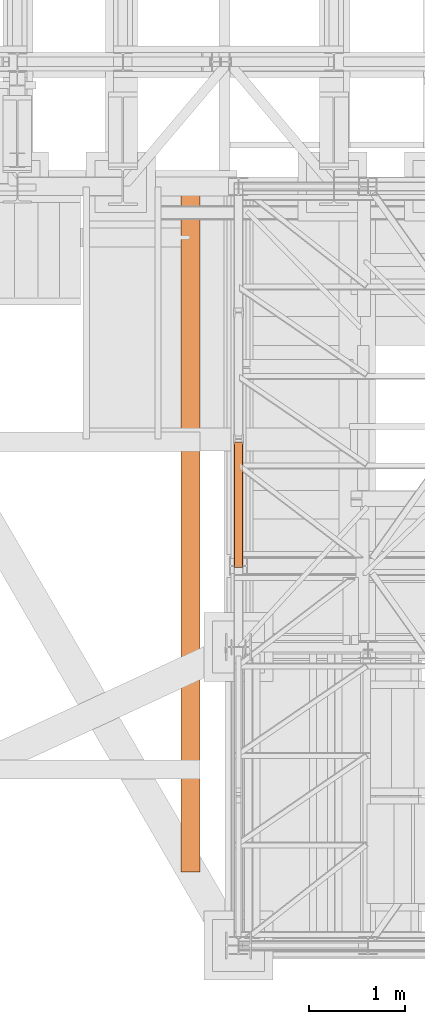
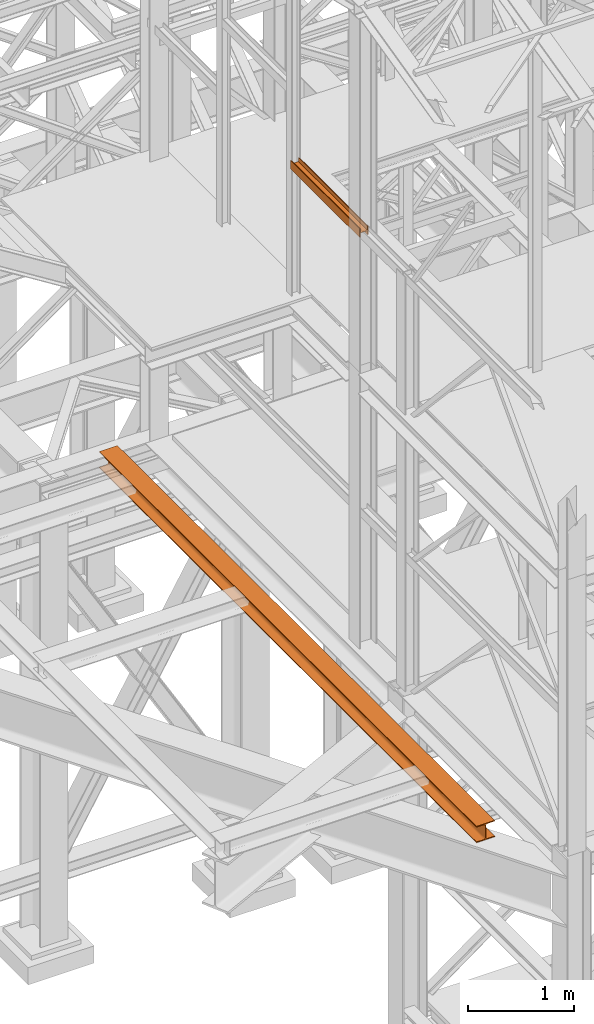
# One storey, part 24 of 208: 3 proxies.
"""IFC2X3 building model written with IfcOpenShell, lengths in millimetres."""

from ifc_helpers import new_model, entity, si_unit, converted_unit, frame, origin, origin_with_axes, place, context, subcontext, project, spatial, faceted_brep, element, save


model = new_model("IFC2X3")

# Units and contexts
model_context = context("Model", 3, precision=1e-05, world=origin())
plan_context = context("Plan", 3, precision=1e-05, world=origin())
body_context = subcontext(model_context, "Body", "Model", "MODEL_VIEW")
ifc_project = project(units=[si_unit("LENGTHUNIT", "METRE", prefix="MILLI"), converted_unit("PLANEANGLEUNIT", "DEGREE", entity("IfcPlaneAngleMeasure", 0.0174532925199433), si_unit("PLANEANGLEUNIT", "RADIAN"), dimensions=[0, 0, 0, 0, 0, 0, 0]), si_unit("AREAUNIT", "SQUARE_METRE"), si_unit("VOLUMEUNIT", "CUBIC_METRE")], contexts=[model_context, plan_context])

# Building, storey
building_placement = place(None, origin())
building = spatial("IfcBuilding", under=ifc_project, at=building_placement, CompositionType="COMPLEX")
storey_placement = place(building_placement, origin_with_axes())
storey = spatial("IfcBuildingStorey", under=building, at=storey_placement, Name="Geschoss", CompositionType="ELEMENT")

# Proxies
proxy_1_placement = place(storey_placement, frame((1150.254968528656, -21234.96003231041, 9977.249663113742), z_axis=(0.0, 0.0, 1.0), x_axis=(1.0, 0.0, 0.0)))
element("IfcBuildingElementProxy", 1, at=proxy_1_placement, inside=storey, context=body_context, shape_type="Brep", body=[
    faceted_brep([(8.009999999999991, 0.00999999999839929, 0.01000000000021828), (0.009999999999990905, 0.00999999999839929, 0.01000000000021828), (0.009999999999990905, 0.00999999999839929, 100.0100000000002), (8.009999999999991, 0.00999999999839929, 100.0100000000002), (8.009999999999991, 0.00999999999839929, 52.51000000000022), (88.00999999999999, 0.00999999999839929, 52.51000000000022), (88.00999999999999, 0.00999999999839929, 100.0100000000002), (96.00999999999999, 0.00999999999839929, 100.0100000000002), (96.00999999999999, 0.00999999999839929, 0.01000000000021828), (88.00999999999999, 0.00999999999839929, 0.01000000000021828), (88.00999999999999, 0.00999999999839929, 47.51000000000022), (8.009999999999991, 0.00999999999839929, 47.51000000000022), (0.009999999999990905, 0.00999999999839929, 0.01000000000021828), (8.009999999999991, 0.00999999999839929, 0.01000000000021828), (8.009999999999991, 1312.395641619994, 0.01000000000021828), (0.009999999999990905, 1312.395641619994, 0.01000000000021828), (0.009999999999990905, 0.00999999999839929, 100.0100000000002), (0.009999999999990905, 0.00999999999839929, 0.01000000000021828), (0.009999999999990905, 1312.395641619994, 0.01000000000021828), (0.009999999999990905, 1312.395641619994, 100.0100000000002), (8.009999999999991, 0.00999999999839929, 100.0100000000002), (0.009999999999990905, 0.00999999999839929, 100.0100000000002), (0.009999999999990905, 1312.395641619994, 100.0100000000002), (8.009999999999991, 1312.395641619994, 100.0100000000002), (8.009999999999991, 0.00999999999839929, 52.51000000000022), (8.009999999999991, 0.00999999999839929, 100.0100000000002), (8.009999999999991, 1312.395641619994, 100.0100000000002), (8.009999999999991, 1312.395641619994, 52.51000000000022), (88.00999999999999, 0.00999999999839929, 52.51000000000022), (8.009999999999991, 0.00999999999839929, 52.51000000000022), (8.009999999999991, 1312.395641619994, 52.51000000000022), (88.00999999999999, 1312.395641619994, 52.51000000000022), (88.00999999999999, 0.00999999999839929, 100.0100000000002), (88.00999999999999, 0.00999999999839929, 52.51000000000022), (88.00999999999999, 1312.395641619994, 52.51000000000022), (88.00999999999999, 1312.395641619994, 100.0100000000002), (96.00999999999999, 0.00999999999839929, 100.0100000000002), (88.00999999999999, 0.00999999999839929, 100.0100000000002), (88.00999999999999, 1312.395641619994, 100.0100000000002), (96.00999999999999, 1312.395641619994, 100.0100000000002), (96.00999999999999, 0.00999999999839929, 0.01000000000021828), (96.00999999999999, 0.00999999999839929, 100.0100000000002), (96.00999999999999, 1312.395641619994, 100.0100000000002), (96.00999999999999, 1312.395641619994, 0.01000000000021828), (88.00999999999999, 0.00999999999839929, 0.01000000000021828), (96.00999999999999, 0.00999999999839929, 0.01000000000021828), (96.00999999999999, 1312.395641619994, 0.01000000000021828), (88.00999999999999, 1312.395641619994, 0.01000000000021828), (88.00999999999999, 0.00999999999839929, 47.51000000000022), (88.00999999999999, 0.00999999999839929, 0.01000000000021828), (88.00999999999999, 1312.395641619994, 0.01000000000021828), (88.00999999999999, 1312.395641619994, 47.51000000000022), (8.009999999999991, 0.00999999999839929, 47.51000000000022), (88.00999999999999, 0.00999999999839929, 47.51000000000022), (88.00999999999999, 1312.395641619994, 47.51000000000022), (8.009999999999991, 1312.395641619994, 47.51000000000022), (8.009999999999991, 0.00999999999839929, 0.01000000000021828), (8.009999999999991, 0.00999999999839929, 47.51000000000022), (8.009999999999991, 1312.395641619994, 47.51000000000022), (8.009999999999991, 1312.395641619994, 0.01000000000021828), (8.009999999999991, 1312.395641619994, 0.01000000000021828), (8.009999999999991, 1312.395641619994, 47.51000000000022), (88.00999999999999, 1312.395641619994, 47.51000000000022), (88.00999999999999, 1312.395641619994, 0.01000000000021828), (96.00999999999999, 1312.395641619994, 0.01000000000021828), (96.00999999999999, 1312.395641619994, 100.0100000000002), (88.00999999999999, 1312.395641619994, 100.0100000000002), (88.00999999999999, 1312.395641619994, 52.51000000000022), (8.009999999999991, 1312.395641619994, 52.51000000000022), (8.009999999999991, 1312.395641619994, 100.0100000000002), (0.009999999999990905, 1312.395641619994, 100.0100000000002), (0.009999999999990905, 1312.395641619994, 0.01000000000021828)], [[[0, 1, 2, 3, 4, 5, 6, 7, 8, 9, 10, 11]], [[12, 13, 14, 15]], [[16, 17, 18, 19]], [[20, 21, 22, 23]], [[24, 25, 26, 27]], [[28, 29, 30, 31]], [[32, 33, 34, 35]], [[36, 37, 38, 39]], [[40, 41, 42, 43]], [[44, 45, 46, 47]], [[48, 49, 50, 51]], [[52, 53, 54, 55]], [[56, 57, 58, 59]], [[60, 61, 62, 63, 64, 65, 66, 67, 68, 69, 70, 71]]], orient=[[False], [False], [False], [False], [False], [False], [False], [False], [False], [False], [False], [False], [False], [False]]),
])
proxy_2_placement = place(storey_placement, frame((1150.254968528656, -21234.96003231041, 9977.249663113742), z_axis=(0.0, 0.0, 1.0), x_axis=(1.0, 0.0, 0.0)))
element("IfcBuildingElementProxy", 2, at=proxy_2_placement, inside=storey, context=body_context, shape_type="Brep", body=[
    faceted_brep([(8.009999999999991, 0.00999999999839929, 0.01000000000021828), (0.009999999999990905, 0.00999999999839929, 0.01000000000021828), (0.009999999999990905, 0.00999999999839929, 100.0100000000002), (8.009999999999991, 0.00999999999839929, 100.0100000000002), (8.009999999999991, 0.00999999999839929, 52.51000000000022), (88.00999999999999, 0.00999999999839929, 52.51000000000022), (88.00999999999999, 0.00999999999839929, 100.0100000000002), (96.00999999999999, 0.00999999999839929, 100.0100000000002), (96.00999999999999, 0.00999999999839929, 0.01000000000021828), (88.00999999999999, 0.00999999999839929, 0.01000000000021828), (88.00999999999999, 0.00999999999839929, 47.51000000000022), (8.009999999999991, 0.00999999999839929, 47.51000000000022), (0.009999999999990905, 0.00999999999839929, 0.01000000000021828), (8.009999999999991, 0.00999999999839929, 0.01000000000021828), (8.009999999999991, 1312.395641619994, 0.01000000000021828), (0.009999999999990905, 1312.395641619994, 0.01000000000021828), (0.009999999999990905, 0.00999999999839929, 100.0100000000002), (0.009999999999990905, 0.00999999999839929, 0.01000000000021828), (0.009999999999990905, 1312.395641619994, 0.01000000000021828), (0.009999999999990905, 1312.395641619994, 100.0100000000002), (8.009999999999991, 0.00999999999839929, 100.0100000000002), (0.009999999999990905, 0.00999999999839929, 100.0100000000002), (0.009999999999990905, 1312.395641619994, 100.0100000000002), (8.009999999999991, 1312.395641619994, 100.0100000000002), (8.009999999999991, 0.00999999999839929, 52.51000000000022), (8.009999999999991, 0.00999999999839929, 100.0100000000002), (8.009999999999991, 1312.395641619994, 100.0100000000002), (8.009999999999991, 1312.395641619994, 52.51000000000022), (88.00999999999999, 0.00999999999839929, 52.51000000000022), (8.009999999999991, 0.00999999999839929, 52.51000000000022), (8.009999999999991, 1312.395641619994, 52.51000000000022), (88.00999999999999, 1312.395641619994, 52.51000000000022), (88.00999999999999, 0.00999999999839929, 100.0100000000002), (88.00999999999999, 0.00999999999839929, 52.51000000000022), (88.00999999999999, 1312.395641619994, 52.51000000000022), (88.00999999999999, 1312.395641619994, 100.0100000000002), (96.00999999999999, 0.00999999999839929, 100.0100000000002), (88.00999999999999, 0.00999999999839929, 100.0100000000002), (88.00999999999999, 1312.395641619994, 100.0100000000002), (96.00999999999999, 1312.395641619994, 100.0100000000002), (96.00999999999999, 0.00999999999839929, 0.01000000000021828), (96.00999999999999, 0.00999999999839929, 100.0100000000002), (96.00999999999999, 1312.395641619994, 100.0100000000002), (96.00999999999999, 1312.395641619994, 0.01000000000021828), (88.00999999999999, 0.00999999999839929, 0.01000000000021828), (96.00999999999999, 0.00999999999839929, 0.01000000000021828), (96.00999999999999, 1312.395641619994, 0.01000000000021828), (88.00999999999999, 1312.395641619994, 0.01000000000021828), (88.00999999999999, 0.00999999999839929, 47.51000000000022), (88.00999999999999, 0.00999999999839929, 0.01000000000021828), (88.00999999999999, 1312.395641619994, 0.01000000000021828), (88.00999999999999, 1312.395641619994, 47.51000000000022), (8.009999999999991, 0.00999999999839929, 47.51000000000022), (88.00999999999999, 0.00999999999839929, 47.51000000000022), (88.00999999999999, 1312.395641619994, 47.51000000000022), (8.009999999999991, 1312.395641619994, 47.51000000000022), (8.009999999999991, 0.00999999999839929, 0.01000000000021828), (8.009999999999991, 0.00999999999839929, 47.51000000000022), (8.009999999999991, 1312.395641619994, 47.51000000000022), (8.009999999999991, 1312.395641619994, 0.01000000000021828), (8.009999999999991, 1312.395641619994, 0.01000000000021828), (8.009999999999991, 1312.395641619994, 47.51000000000022), (88.00999999999999, 1312.395641619994, 47.51000000000022), (88.00999999999999, 1312.395641619994, 0.01000000000021828), (96.00999999999999, 1312.395641619994, 0.01000000000021828), (96.00999999999999, 1312.395641619994, 100.0100000000002), (88.00999999999999, 1312.395641619994, 100.0100000000002), (88.00999999999999, 1312.395641619994, 52.51000000000022), (8.009999999999991, 1312.395641619994, 52.51000000000022), (8.009999999999991, 1312.395641619994, 100.0100000000002), (0.009999999999990905, 1312.395641619994, 100.0100000000002), (0.009999999999990905, 1312.395641619994, 0.01000000000021828)], [[[0, 1, 2, 3, 4, 5, 6, 7, 8, 9, 10, 11]], [[12, 13, 14, 15]], [[16, 17, 18, 19]], [[20, 21, 22, 23]], [[24, 25, 26, 27]], [[28, 29, 30, 31]], [[32, 33, 34, 35]], [[36, 37, 38, 39]], [[40, 41, 42, 43]], [[44, 45, 46, 47]], [[48, 49, 50, 51]], [[52, 53, 54, 55]], [[56, 57, 58, 59]], [[60, 61, 62, 63, 64, 65, 66, 67, 68, 69, 70, 71]]], orient=[[False], [False], [False], [False], [False], [False], [False], [False], [False], [False], [False], [False], [False], [False]]),
])
proxy_3_placement = place(storey_placement, frame((598.2549685286633, -24404.76773812424, 5094.990005364416), z_axis=(0.0, 0.0, 1.0), x_axis=(1.0, 0.0, 0.0)))
element("IfcBuildingElementProxy", 3, at=proxy_3_placement, inside=storey, context=body_context, shape_type="Brep", body=[
    faceted_brep([(200.01, 7147.273876318883, 0.01000000000021828), (200.0099999999991, 0.01000000000203727, 0.01000000000021828), (200.0099999999991, 0.01000000000203727, 10.01000000000022), (200.01, 7147.273876318883, 10.01000000000022), (200.01, 7147.273876318883, 10.01000000000022), (200.0099999999991, 0.01000000000203727, 10.01000000000022), (121.2599999999991, 0.01000000000203727, 10.01000000000022), (121.26, 7147.273876318883, 10.01000000000022), (121.26, 7147.273876318883, 10.01000000000022), (121.2599999999991, 0.01000000000203727, 10.01000000000022), (115.6977129694249, 0.01000000000203727, 10.89104403849342), (115.6977129694258, 7147.273876318883, 10.89104403849342), (115.6977129694258, 7147.273876318883, 10.89104403849342), (115.6977129694249, 0.01000000000203727, 10.89104403849342), (110.6798832894644, 0.01000000000203727, 13.44771635773213), (110.6798832894654, 7147.273876318883, 13.44771635773213), (110.6798832894654, 7147.273876318883, 13.44771635773213), (110.6798832894644, 0.01000000000203727, 13.44771635773213), (106.6977163577328, 0.01000000000203727, 17.42988328946558), (106.6977163577337, 7147.273876318883, 17.42988328946558), (106.6977163577337, 7147.273876318883, 17.42988328946558), (106.6977163577328, 0.01000000000203727, 17.42988328946558), (104.1410440384941, 0.01000000000203727, 22.44771296942599), (104.141044038495, 7147.273876318883, 22.44771296942599), (104.141044038495, 7147.273876318883, 22.44771296942599), (104.1410440384941, 0.01000000000203727, 22.44771296942599), (103.2599999999991, 0.01000000000203727, 28.01000000000022), (103.26, 7147.273876318883, 28.01000000000022), (103.26, 7147.273876318883, 28.01000000000022), (103.2599999999991, 0.01000000000203727, 28.01000000000022), (103.2599999999991, 0.01000000000203727, 162.0100000000002), (103.26, 7147.273876318883, 162.0100000000002), (103.26, 7147.273876318883, 162.0100000000002), (103.2599999999991, 0.01000000000203727, 162.0100000000002), (104.1410440384941, 0.01000000000203727, 167.5722870305744), (104.141044038495, 7147.273876318883, 167.5722870305744), (104.141044038495, 7147.273876318883, 167.5722870305744), (104.1410440384941, 0.01000000000203727, 167.5722870305744), (106.6977163577328, 0.01000000000203727, 172.5901167105349), (106.6977163577337, 7147.273876318883, 172.5901167105349), (106.6977163577337, 7147.273876318883, 172.5901167105349), (106.6977163577328, 0.01000000000203727, 172.5901167105349), (110.6798832894644, 0.01000000000203727, 176.5722836422683), (110.6798832894654, 7147.273876318883, 176.5722836422683), (110.6798832894654, 7147.273876318883, 176.5722836422683), (110.6798832894644, 0.01000000000203727, 176.5722836422683), (115.6977129694249, 0.01000000000203727, 179.128955961507), (115.6977129694258, 7147.273876318883, 179.128955961507), (115.6977129694258, 7147.273876318883, 179.128955961507), (115.6977129694249, 0.01000000000203727, 179.128955961507), (120.0099999999991, 0.01000000000203727, 180.0100000000002), (120.01, 7147.273876318883, 180.0100000000002), (120.01, 7147.273876318883, 180.0100000000002), (120.0099999999991, 0.01000000000203727, 180.0100000000002), (200.0099999999991, 0.01000000000203727, 180.0100000000002), (200.01, 7147.273876318883, 180.0100000000002), (200.01, 7147.273876318883, 180.0100000000002), (200.0099999999991, 0.01000000000203727, 180.0100000000002), (200.0099999999991, 0.01000000000203727, 190.0100000000002), (200.01, 7147.273876318883, 190.0100000000002), (200.01, 7147.273876318883, 190.0100000000002), (200.0099999999991, 0.01000000000203727, 190.0100000000002), (0.009999999999990905, 0.01000000000203727, 190.0100000000002), (0.009999999999990905, 7147.273876318883, 190.0100000000002), (0.009999999999990905, 7147.273876318883, 190.0100000000002), (0.009999999999990905, 0.01000000000203727, 190.0100000000002), (0.009999999999990905, 0.01000000000203727, 180.0100000000002), (0.009999999999990905, 7147.273876318883, 180.0100000000002), (0.009999999999990905, 7147.273876318883, 180.0100000000002), (0.009999999999990905, 0.01000000000203727, 180.0100000000002), (78.75999999999908, 0.01000000000203727, 180.0100000000002), (78.75999999999999, 7147.273876318883, 180.0100000000002), (78.75999999999999, 7147.273876318883, 180.0100000000002), (78.75999999999908, 0.01000000000203727, 180.0100000000002), (84.3222870305733, 0.01000000000203727, 179.128955961507), (84.32228703057422, 7147.273876318883, 179.128955961507), (84.32228703057422, 7147.273876318883, 179.128955961507), (84.3222870305733, 0.01000000000203727, 179.128955961507), (89.34011671053372, 0.01000000000203727, 176.5722836422683), (89.34011671053463, 7147.273876318883, 176.5722836422683), (89.34011671053463, 7147.273876318883, 176.5722836422683), (89.34011671053372, 0.01000000000203727, 176.5722836422683), (93.32228364226899, 0.01000000000203727, 172.5901167105349), (93.3222836422699, 7147.273876318883, 172.5901167105349), (93.3222836422699, 7147.273876318883, 172.5901167105349), (93.32228364226899, 0.01000000000203727, 172.5901167105349), (95.87895596150406, 0.01000000000203727, 167.5722870305744), (95.87895596150497, 7147.273876318883, 167.5722870305744), (95.87895596150497, 7147.273876318883, 167.5722870305744), (95.87895596150406, 0.01000000000203727, 167.5722870305744), (96.75999999999908, 0.01000000000203727, 162.0100000000002), (96.75999999999999, 7147.273876318883, 162.0100000000002), (96.75999999999999, 7147.273876318883, 162.0100000000002), (96.75999999999908, 0.01000000000203727, 162.0100000000002), (96.75999999999908, 0.01000000000203727, 28.01000000000022), (96.75999999999999, 7147.273876318883, 28.01000000000022), (96.75999999999999, 7147.273876318883, 28.01000000000022), (96.75999999999908, 0.01000000000203727, 28.01000000000022), (95.87895596150406, 0.01000000000203727, 22.44771296942599), (95.87895596150497, 7147.273876318883, 22.44771296942599), (95.87895596150497, 7147.273876318883, 22.44771296942599), (95.87895596150406, 0.01000000000203727, 22.44771296942599), (93.32228364226899, 0.01000000000203727, 17.42988328946558), (93.3222836422699, 7147.273876318883, 17.42988328946558), (93.3222836422699, 7147.273876318883, 17.42988328946558), (93.32228364226899, 0.01000000000203727, 17.42988328946558), (89.34011671053372, 0.01000000000203727, 13.44771635773213), (89.34011671053463, 7147.273876318883, 13.44771635773213), (89.34011671053463, 7147.273876318883, 13.44771635773213), (89.34011671053372, 0.01000000000203727, 13.44771635773213), (84.3222870305733, 0.01000000000203727, 10.89104403849342), (84.32228703057422, 7147.273876318883, 10.89104403849342), (84.32228703057422, 7147.273876318883, 10.89104403849342), (84.3222870305733, 0.01000000000203727, 10.89104403849342), (78.75999999999908, 0.01000000000203727, 10.01000000000022), (78.75999999999999, 7147.273876318883, 10.01000000000022), (78.75999999999999, 7147.273876318883, 10.01000000000022), (78.75999999999908, 0.01000000000203727, 10.01000000000022), (0.009999999999990905, 0.01000000000203727, 10.01000000000022), (0.009999999999990905, 7147.273876318883, 10.01000000000022), (0.009999999999990905, 7147.273876318883, 10.01000000000022), (0.009999999999990905, 0.01000000000203727, 10.01000000000022), (0.009999999999990905, 0.01000000000203727, 0.01000000000021828), (0.009999999999990905, 7147.273876318883, 0.01000000000021828), (0.009999999999990905, 7147.273876318883, 0.01000000000021828), (0.009999999999990905, 0.01000000000203727, 0.01000000000021828), (200.0099999999991, 0.01000000000203727, 0.01000000000021828), (200.01, 7147.273876318883, 0.01000000000021828), (200.01, 7147.273876318883, 0.01000000000021828), (200.01, 7147.273876318883, 10.01000000000022), (121.26, 7147.273876318883, 10.01000000000022), (115.6977129694258, 7147.273876318883, 10.89104403849342), (110.6798832894654, 7147.273876318883, 13.44771635773213), (106.6977163577337, 7147.273876318883, 17.42988328946558), (104.141044038495, 7147.273876318883, 22.44771296942599), (103.26, 7147.273876318883, 28.01000000000022), (103.26, 7147.273876318883, 162.0100000000002), (104.141044038495, 7147.273876318883, 167.5722870305744), (106.6977163577337, 7147.273876318883, 172.5901167105349), (110.6798832894654, 7147.273876318883, 176.5722836422683), (115.6977129694258, 7147.273876318883, 179.128955961507), (120.01, 7147.273876318883, 180.0100000000002), (200.01, 7147.273876318883, 180.0100000000002), (200.01, 7147.273876318883, 190.0100000000002), (0.009999999999990905, 7147.273876318883, 190.0100000000002), (0.009999999999990905, 7147.273876318883, 180.0100000000002), (78.75999999999999, 7147.273876318883, 180.0100000000002), (84.32228703057422, 7147.273876318883, 179.128955961507), (89.34011671053463, 7147.273876318883, 176.5722836422683), (93.3222836422699, 7147.273876318883, 172.5901167105349), (95.87895596150497, 7147.273876318883, 167.5722870305744), (96.75999999999999, 7147.273876318883, 162.0100000000002), (96.75999999999999, 7147.273876318883, 28.01000000000022), (95.87895596150497, 7147.273876318883, 22.44771296942599), (93.3222836422699, 7147.273876318883, 17.42988328946558), (89.34011671053463, 7147.273876318883, 13.44771635773213), (84.32228703057422, 7147.273876318883, 10.89104403849342), (78.75999999999999, 7147.273876318883, 10.01000000000022), (0.009999999999990905, 7147.273876318883, 10.01000000000022), (0.009999999999990905, 7147.273876318883, 0.01000000000021828), (200.0099999999991, 0.01000000000203727, 0.01000000000021828), (0.009999999999990905, 0.01000000000203727, 0.01000000000021828), (0.009999999999990905, 0.01000000000203727, 10.01000000000022), (78.75999999999908, 0.01000000000203727, 10.01000000000022), (84.3222870305733, 0.01000000000203727, 10.89104403849342), (89.34011671053372, 0.01000000000203727, 13.44771635773213), (93.32228364226899, 0.01000000000203727, 17.42988328946558), (95.87895596150406, 0.01000000000203727, 22.44771296942599), (96.75999999999908, 0.01000000000203727, 28.01000000000022), (96.75999999999908, 0.01000000000203727, 162.0100000000002), (95.87895596150406, 0.01000000000203727, 167.5722870305744), (93.32228364226899, 0.01000000000203727, 172.5901167105349), (89.34011671053372, 0.01000000000203727, 176.5722836422683), (84.3222870305733, 0.01000000000203727, 179.128955961507), (78.75999999999908, 0.01000000000203727, 180.0100000000002), (0.009999999999990905, 0.01000000000203727, 180.0100000000002), (0.009999999999990905, 0.01000000000203727, 190.0100000000002), (200.0099999999991, 0.01000000000203727, 190.0100000000002), (200.0099999999991, 0.01000000000203727, 180.0100000000002), (120.0099999999991, 0.01000000000203727, 180.0100000000002), (115.6977129694249, 0.01000000000203727, 179.128955961507), (110.6798832894644, 0.01000000000203727, 176.5722836422683), (106.6977163577328, 0.01000000000203727, 172.5901167105349), (104.1410440384941, 0.01000000000203727, 167.5722870305744), (103.2599999999991, 0.01000000000203727, 162.0100000000002), (103.2599999999991, 0.01000000000203727, 28.01000000000022), (104.1410440384941, 0.01000000000203727, 22.44771296942599), (106.6977163577328, 0.01000000000203727, 17.42988328946558), (110.6798832894644, 0.01000000000203727, 13.44771635773213), (115.6977129694249, 0.01000000000203727, 10.89104403849342), (121.2599999999991, 0.01000000000203727, 10.01000000000022), (200.0099999999991, 0.01000000000203727, 10.01000000000022)], [[[0, 1, 2, 3]], [[4, 5, 6, 7]], [[8, 9, 10, 11]], [[12, 13, 14, 15]], [[16, 17, 18, 19]], [[20, 21, 22, 23]], [[24, 25, 26, 27]], [[28, 29, 30, 31]], [[32, 33, 34, 35]], [[36, 37, 38, 39]], [[40, 41, 42, 43]], [[44, 45, 46, 47]], [[48, 49, 50, 51]], [[52, 53, 54, 55]], [[56, 57, 58, 59]], [[60, 61, 62, 63]], [[64, 65, 66, 67]], [[68, 69, 70, 71]], [[72, 73, 74, 75]], [[76, 77, 78, 79]], [[80, 81, 82, 83]], [[84, 85, 86, 87]], [[88, 89, 90, 91]], [[92, 93, 94, 95]], [[96, 97, 98, 99]], [[100, 101, 102, 103]], [[104, 105, 106, 107]], [[108, 109, 110, 111]], [[112, 113, 114, 115]], [[116, 117, 118, 119]], [[120, 121, 122, 123]], [[124, 125, 126, 127]], [[128, 129, 130, 131, 132, 133, 134, 135, 136, 137, 138, 139, 140, 141, 142, 143, 144, 145, 146, 147, 148, 149, 150, 151, 152, 153, 154, 155, 156, 157, 158, 159]], [[160, 161, 162, 163, 164, 165, 166, 167, 168, 169, 170, 171, 172, 173, 174, 175, 176, 177, 178, 179, 180, 181, 182, 183, 184, 185, 186, 187, 188, 189, 190, 191]]], orient=[[False], [False], [False], [False], [False], [False], [False], [False], [False], [False], [False], [False], [False], [False], [False], [False], [False], [False], [False], [False], [False], [False], [False], [False], [False], [False], [False], [False], [False], [False], [False], [False], [False], [False]]),
])

save(model, "model.ifc")
